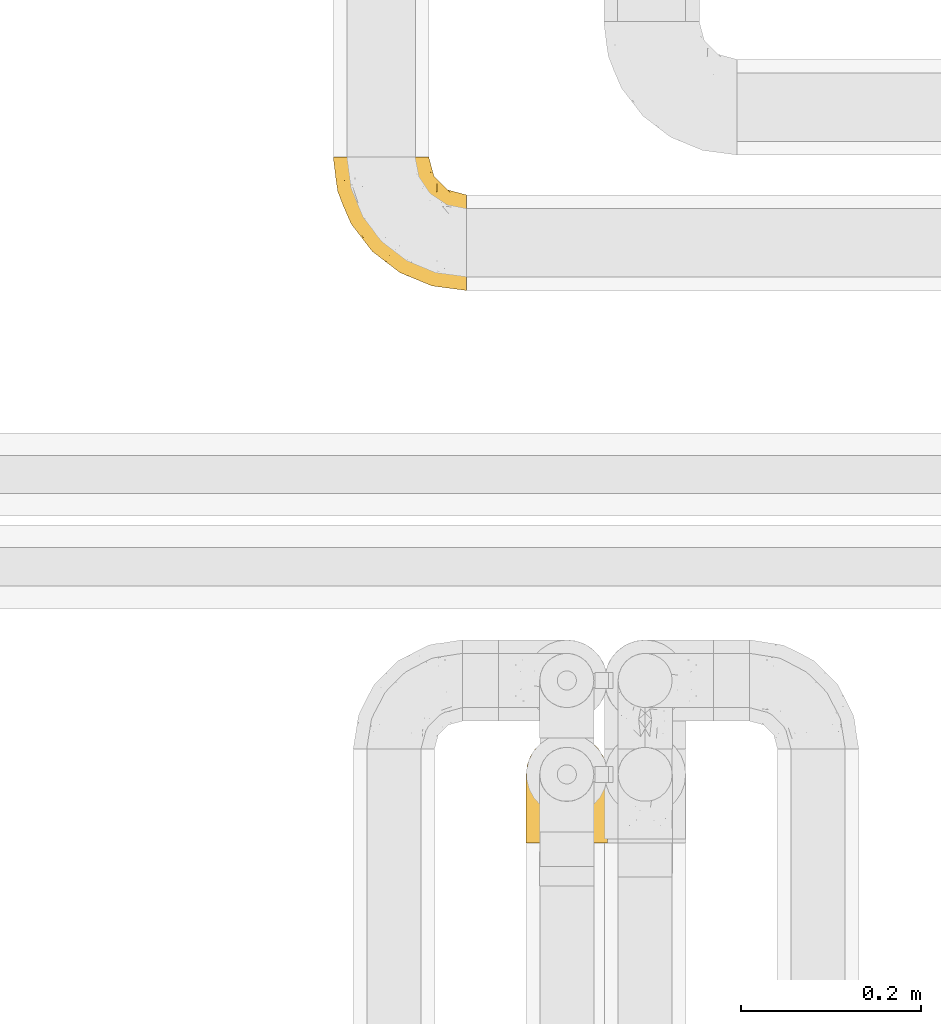
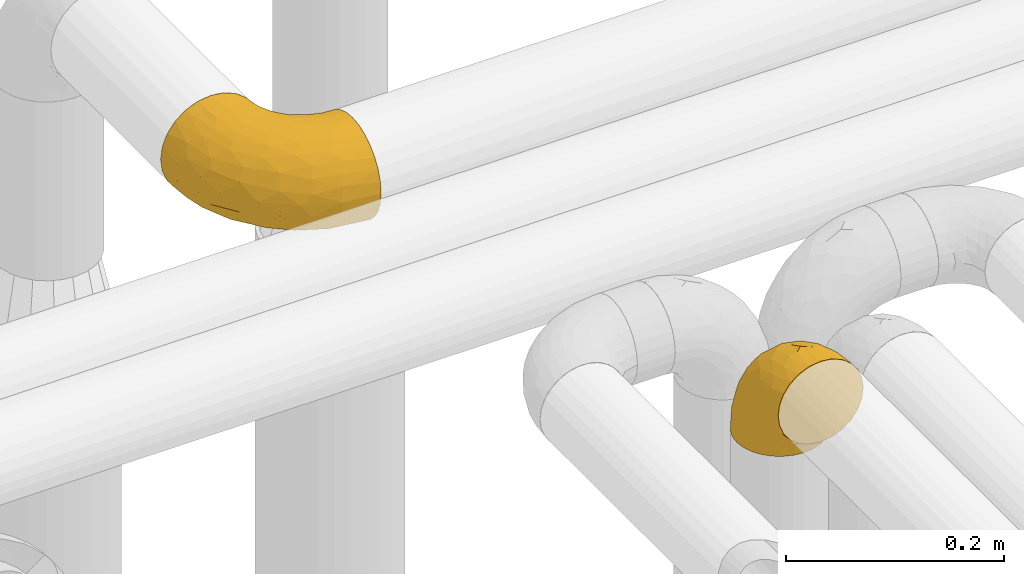
# One storey, part 314 of 827: 2 coverings.
"""IFC2X3 building model written with IfcOpenShell, lengths in millimetres."""

import ifcopenshell
import ifcopenshell.guid

model = None  # the IFC model being written
_history = None  # IfcOwnerHistory: only IFC2X3 demands one
_inside = {}  # id of a spatial element -> (the spatial element, [elements in it])
_under = {}  # id of a project, library or spatial element -> (it, [spatial elements below it])
_declared = {}  # id of a project -> (the project, [libraries it declares])
_typed = {}  # id of a type object -> (the type object, [elements of that type])
_made_of = {}  # id of a material, layer set ... -> (it, [elements and type objects made of it])


def new_model(schema):
    """Start an empty IFC model of exactly this schema.

    Asked for "IFC4X3", IfcOpenShell would pick the latest addendum, in which some entities
    have other attributes; the version numbers below select the first issue.
    IFC2X3 requires an IfcOwnerHistory on every rooted entity: one is made here for all.
    """
    global model, _history
    if schema == "IFC4X3":
        model = ifcopenshell.file(schema_version=(4, 3, 0, 0))
    else:
        model = ifcopenshell.file(schema=schema)
    _inside.clear()
    _under.clear()
    _declared.clear()
    _typed.clear()
    _made_of.clear()
    _history = None
    if model.schema == "IFC2X3":
        org = make("IfcOrganization", Name="unknown")
        user = make(
            "IfcPersonAndOrganization",
            ThePerson=make("IfcPerson", FamilyName="unknown"),
            TheOrganization=org,
        )
        app = make(
            "IfcApplication",
            ApplicationDeveloper=org,
            Version="unknown",
            ApplicationFullName="unknown",
            ApplicationIdentifier="unknown",
        )
        _history = make(
            "IfcOwnerHistory",
            OwningUser=user,
            OwningApplication=app,
            ChangeAction="ADDED",
            CreationDate=0,
        )
    return model


def make(cls, **values):
    """One entity of the class cls with the attributes given. An attribute that is None is left unset."""
    return model.create_entity(
        cls, **{name: value for name, value in values.items() if value is not None}
    )


def entity(cls, *values):
    """Any entity or typed value of the class cls, its attributes in the order of the schema. None: left unset."""
    e = model.create_entity(cls)
    for i, value in enumerate(values):
        if value is not None:
            e[i] = value
    return e


def rooted(cls, **values):
    """An entity with a GlobalId (a new one), such as an element, a storey or a relation."""
    return make(cls, GlobalId=ifcopenshell.guid.new(), OwnerHistory=_history, **values)


def si_unit(unit_type, name, prefix=None):
    """IfcSIUnit, for example si_unit("LENGTHUNIT", "METRE", prefix="MILLI")."""
    return make("IfcSIUnit", UnitType=unit_type, Prefix=prefix, Name=name)


def converted_unit(unit_type, name, factor, base, dimensions=None, offset=None):
    """IfcConversionBasedUnit, such as the inch: factor (a typed value) times the base unit."""
    return make(
        "IfcConversionBasedUnit"
        if offset is None
        else "IfcConversionBasedUnitWithOffset",
        ConversionOffset=offset,
        Dimensions=None
        if dimensions is None
        else entity("IfcDimensionalExponents", *dimensions),
        UnitType=unit_type,
        Name=name,
        ConversionFactor=make(
            "IfcMeasureWithUnit", ValueComponent=factor, UnitComponent=base
        ),
    )


def derived_unit(unit_type, elements):
    """IfcDerivedUnit: a product of units, each with its exponent."""
    return make(
        "IfcDerivedUnit",
        Elements=[
            make("IfcDerivedUnitElement", Unit=unit, Exponent=power)
            for unit, power in elements
        ],
        UnitType=unit_type,
    )


def assignment(units):
    """IfcUnitAssignment: the units of a project."""
    return None if units is None else make("IfcUnitAssignment", Units=units)


def point(xyz):
    """IfcCartesianPoint."""
    return None if xyz is None else make("IfcCartesianPoint", Coordinates=xyz)


def direction(xyz):
    """IfcDirection."""
    return None if xyz is None else make("IfcDirection", DirectionRatios=xyz)


def frame(location, z_axis=None, x_axis=None):
    """IfcAxis2Placement3D, a coordinate frame: its origin and axes. An axis left out is left unset."""
    return make(
        "IfcAxis2Placement3D",
        Location=point(location),
        Axis=direction(z_axis),
        RefDirection=direction(x_axis),
    )


def origin():
    """The frame at (0, 0, 0) with its axes left unset."""
    return frame((0.0, 0.0, 0.0))


def place(relative_to, where):
    """IfcLocalPlacement: puts the frame where relative to a parent placement (None: the world)."""
    return make(
        "IfcLocalPlacement", PlacementRelTo=relative_to, RelativePlacement=where
    )


def context(
    kind, dimensions, precision=None, world=None, true_north=None, identifier=None
):
    """IfcGeometricRepresentationContext, for example the 3D "Model" context."""
    return make(
        "IfcGeometricRepresentationContext",
        ContextIdentifier=identifier,
        ContextType=kind,
        CoordinateSpaceDimension=dimensions,
        Precision=precision,
        WorldCoordinateSystem=world,
        TrueNorth=true_north,
    )


def subcontext(parent, identifier, kind, view, scale=None):
    """IfcGeometricRepresentationSubContext, for example "Body" below "Model"."""
    return make(
        "IfcGeometricRepresentationSubContext",
        ContextIdentifier=identifier,
        ContextType=kind,
        ParentContext=parent,
        TargetScale=scale,
        TargetView=view,
    )


def project(units=None, contexts=None):
    """IfcProject with its units and contexts."""
    return rooted(
        "IfcProject",
        Name="project",
        RepresentationContexts=contexts,
        UnitsInContext=assignment(units),
    )


def spatial(cls, under=None, at=None, **own):
    """A site, building, storey or space (cls), placed at a placement, below another one or the project."""
    s = rooted(cls, ObjectPlacement=at, **own)
    if under is not None:
        _under.setdefault(under.id(), (under, []))[1].append(s)
    return s


def faces_of(points, faces, orient=None, outer=None):
    """IfcFace entities. A face is a list of loops; a loop is a list of indices into points, from 0.

    orient and outer hold one flag for each loop. By default every Orientation is true, the
    first loop of a face is its IfcFaceOuterBound and the others are IfcFaceBound.
    """
    made = []
    for i, loops in enumerate(faces):
        bounds = []
        for j, loop in enumerate(loops):
            is_outer = j == 0 if outer is None else outer[i][j]
            bounds.append(
                make(
                    "IfcFaceOuterBound" if is_outer else "IfcFaceBound",
                    Bound=make("IfcPolyLoop", Polygon=[points[k] for k in loop]),
                    Orientation=True if orient is None else orient[i][j],
                )
            )
        made.append(make("IfcFace", Bounds=bounds))
    return made


def faceted_brep(points, faces, orient=None, outer=None, voids=None):
    """IfcFacetedBrep: a solid bounded by flat faces; with voids (closed shells), ...WithVoids."""
    shared = [point(p) for p in points]
    hull = make("IfcClosedShell", CfsFaces=faces_of(shared, faces, orient, outer))
    if voids is None:
        return make("IfcFacetedBrep", Outer=hull)
    return make(
        "IfcFacetedBrepWithVoids",
        Outer=hull,
        Voids=[
            make(cls, CfsFaces=faces_of(shared, fs, o, b)) for cls, fs, o, b in voids
        ],
    )


def shape(context_of_items, identifier, shape_type, items):
    """IfcShapeRepresentation: the items that make up one representation, for example the "Body"."""
    return make(
        "IfcShapeRepresentation",
        ContextOfItems=context_of_items,
        RepresentationIdentifier=identifier,
        RepresentationType=shape_type,
        Items=items,
    )


def made_of(thing, what):
    """Note that an element or type object is made of a material, layer set ...; save() writes the relation."""
    if what is not None:
        _made_of.setdefault(what.id(), (what, []))[1].append(thing)
    return thing


def element(
    cls,
    number,
    at=None,
    inside=None,
    cuts=None,
    type_object=None,
    material=None,
    context=None,
    identifier="Body",
    shape_type=None,
    held_by="IfcProductDefinitionShape",
    body=None,
    shapes=None,
    **own,
):
    """One element of the class cls, such as IfcWall. Its Tag is "e" and its number.

    at: its placement. inside: the storey or other place that contains it. cuts: it is an
    opening in that element (IfcRelVoidsElement). A single representation is given by context,
    identifier, shape_type and body (its items); several are given by shapes. held_by: the class
    of the entity that holds the representations. save() writes the other relations.
    """
    e = rooted(cls, Tag="e%d" % number, ObjectPlacement=at, **own)
    if body is not None:
        shapes = [shape(context, identifier, shape_type, body)]
    if shapes is not None:
        e.Representation = make(held_by, Representations=shapes)
    if inside is not None:
        _inside.setdefault(inside.id(), (inside, []))[1].append(e)
    if cuts is not None:
        rooted(
            "IfcRelVoidsElement", RelatingBuildingElement=cuts, RelatedOpeningElement=e
        )
    if type_object is not None:
        _typed.setdefault(type_object.id(), (type_object, []))[1].append(e)
    return made_of(e, material)


def aggregate(whole, parts):
    """IfcRelAggregates: a whole, such as a stair, and the parts it consists of."""
    return rooted("IfcRelAggregates", RelatingObject=whole, RelatedObjects=parts)


def save(model, path):
    """Write the relations noted so far, then the file.

    IfcRelAggregates (storeys below a building ...), IfcRelContainedInSpatialStructure (elements
    in a storey), IfcRelDefinesByType, IfcRelAssociatesMaterial and IfcRelDeclares: one each for
    every whole, place, type object, material and project.
    """
    for whole, parts in _under.values():
        aggregate(whole, parts)
    for where, things in _inside.values():
        rooted(
            "IfcRelContainedInSpatialStructure",
            RelatedElements=things,
            RelatingStructure=where,
        )
    for kind, things in _typed.values():
        rooted("IfcRelDefinesByType", RelatedObjects=things, RelatingType=kind)
    for what, things in _made_of.values():
        rooted("IfcRelAssociatesMaterial", RelatedObjects=things, RelatingMaterial=what)
    for by, libraries in _declared.values():
        rooted("IfcRelDeclares", RelatingContext=by, RelatedDefinitions=libraries)
    model.write(path)


model = new_model("IFC2X3")

# Units and contexts
model_context = context("Model", 3, precision=0.01, world=origin(), true_north=direction((6.12303176911189e-17, 1.0)))
body_context = subcontext(model_context, "Body", "Model", "MODEL_VIEW")
ifc_project = project(units=[si_unit("LENGTHUNIT", "METRE", prefix="MILLI"), si_unit("AREAUNIT", "SQUARE_METRE"), si_unit("VOLUMEUNIT", "CUBIC_METRE"), converted_unit("PLANEANGLEUNIT", "DEGREE", entity("IfcRatioMeasure", 0.0174532925199433), si_unit("PLANEANGLEUNIT", "RADIAN"), dimensions=[0, 0, 0, 0, 0, 0, 0]), si_unit("MASSUNIT", "GRAM", prefix="KILO"), derived_unit("MASSDENSITYUNIT", [(si_unit("MASSUNIT", "GRAM", prefix="KILO"), 1), (si_unit("LENGTHUNIT", "METRE"), -3)]), derived_unit("MOMENTOFINERTIAUNIT", [(si_unit("LENGTHUNIT", "METRE"), 4)]), si_unit("TIMEUNIT", "SECOND"), si_unit("FREQUENCYUNIT", "HERTZ"), si_unit("THERMODYNAMICTEMPERATUREUNIT", "DEGREE_CELSIUS"), derived_unit("THERMALTRANSMITTANCEUNIT", [(si_unit("MASSUNIT", "GRAM", prefix="KILO"), 1), (si_unit("THERMODYNAMICTEMPERATUREUNIT", "KELVIN"), -1), (si_unit("TIMEUNIT", "SECOND"), -3)]), derived_unit("VOLUMETRICFLOWRATEUNIT", [(si_unit("LENGTHUNIT", "METRE"), 3), (si_unit("TIMEUNIT", "SECOND"), -1)]), derived_unit("MASSFLOWRATEUNIT", [(si_unit("MASSUNIT", "GRAM", prefix="KILO"), 1), (si_unit("TIMEUNIT", "SECOND"), -1)]), derived_unit("ROTATIONALFREQUENCYUNIT", [(si_unit("TIMEUNIT", "SECOND"), -1)]), si_unit("ELECTRICCURRENTUNIT", "AMPERE"), si_unit("ELECTRICVOLTAGEUNIT", "VOLT"), si_unit("POWERUNIT", "WATT"), si_unit("FORCEUNIT", "NEWTON", prefix="KILO"), si_unit("ILLUMINANCEUNIT", "LUX"), si_unit("LUMINOUSFLUXUNIT", "LUMEN"), si_unit("LUMINOUSINTENSITYUNIT", "CANDELA"), derived_unit("USERDEFINED", [(si_unit("MASSUNIT", "GRAM", prefix="KILO"), -1), (si_unit("LENGTHUNIT", "METRE"), -2), (si_unit("TIMEUNIT", "SECOND"), 3), (si_unit("LUMINOUSFLUXUNIT", "LUMEN"), 1)]), derived_unit("LINEARVELOCITYUNIT", [(si_unit("LENGTHUNIT", "METRE"), 1), (si_unit("TIMEUNIT", "SECOND"), -1)]), si_unit("PRESSUREUNIT", "PASCAL"), derived_unit("USERDEFINED", [(si_unit("LENGTHUNIT", "METRE"), -2), (si_unit("MASSUNIT", "GRAM", prefix="KILO"), 1), (si_unit("TIMEUNIT", "SECOND"), -2)]), derived_unit("LINEARFORCEUNIT", [(si_unit("MASSUNIT", "GRAM", prefix="KILO"), 1), (si_unit("LENGTHUNIT", "METRE"), 1), (si_unit("TIMEUNIT", "SECOND"), -2), (si_unit("LENGTHUNIT", "METRE"), -1)]), derived_unit("PLANARFORCEUNIT", [(si_unit("MASSUNIT", "GRAM", prefix="KILO"), 1), (si_unit("LENGTHUNIT", "METRE"), 1), (si_unit("TIMEUNIT", "SECOND"), -2), (si_unit("LENGTHUNIT", "METRE"), -2)])], contexts=[model_context])

# Site, building, storey
site_placement = place(None, origin())
site = spatial("IfcSite", under=ifc_project, at=site_placement, CompositionType="ELEMENT")
building_placement = place(site_placement, origin())
building = spatial("IfcBuilding", under=site, at=building_placement, CompositionType="ELEMENT")
storey_placement = place(building_placement, frame((0.0, 0.0, 28200.0)))
storey = spatial("IfcBuildingStorey", under=building, at=storey_placement, Name="08", CompositionType="ELEMENT", Elevation=28200.0)

# Coverings
covering_1_placement = place(storey_placement, frame((31614.92, 18289.35, 2922.4)))
element("IfcCovering", 1, at=covering_1_placement, inside=storey, Name=":ADSK_", ObjectType=":ADSK_", PredefinedType="INSULATION", context=body_context, shape_type="Brep", body=[
    faceted_brep([(2.73, 87.65, 1.6), (6.07, 97.19, 1.6), (11.45, 105.75, 1.6), (18.6, 112.9, 1.6), (27.16, 118.28, 1.6), (36.7, 121.61, 1.6), (46.75, 122.75, 1.6), (56.8, 121.61, 1.6), (66.34, 118.27, 1.6), (74.9, 112.89, 1.6), (82.05, 105.74, 1.6), (87.43, 97.18, 1.6), (90.76, 87.64, 1.6), (91.9, 77.6, 1.6), (90.76, 67.54, 1.6), (87.42, 58.0, 1.6), (82.04, 49.44, 1.6), (74.89, 42.29, 1.6), (66.33, 36.91, 1.6), (56.79, 33.58, 1.6), (46.75, 32.45, 1.6), (36.69, 33.58, 1.6), (27.15, 36.92, 1.6), (18.59, 42.3, 1.6), (11.44, 49.45, 1.6), (6.06, 58.01, 1.6), (2.73, 67.55, 1.6), (1.6, 77.6, 1.6), (58.43, 1.6, 33.98), (69.32, 1.6, 38.49), (78.67, 1.6, 45.67), (85.85, 1.6, 55.02), (90.36, 1.6, 65.91), (91.9, 1.6, 77.6), (90.36, 1.6, 89.28), (85.85, 1.6, 100.17), (78.67, 1.6, 109.52), (69.32, 1.6, 116.7), (58.43, 1.6, 121.21), (46.75, 1.6, 122.75), (35.06, 1.6, 121.21), (24.17, 1.6, 116.7), (14.82, 1.6, 109.52), (7.64, 1.6, 100.17), (3.13, 1.6, 89.28), (1.6, 1.6, 77.6), (3.13, 1.6, 65.91), (7.64, 1.6, 55.02), (14.82, 1.6, 45.67), (24.17, 1.6, 38.49), (35.06, 1.6, 33.98), (46.75, 1.6, 32.45), (46.75, 99.61, 72.81), (38.29, 95.26, 77.17), (46.75, 86.21, 86.21), (46.75, 39.03, 116.82), (38.96, 30.75, 118.49), (46.75, 23.8, 119.23), (33.86, 60.8, 105.14), (31.42, 85.37, 85.37), (21.63, 73.64, 89.33), (30.84, 31.01, 116.14), (22.16, 49.14, 105.06), (20.56, 23.88, 112.15), (2.29, 82.74, 22.95), (7.18, 43.48, 89.91), (12.6, 29.47, 103.39), (14.0, 56.38, 93.6), (2.81, 72.18, 51.41), (6.65, 72.24, 67.71), (6.11, 87.6, 43.53), (16.62, 107.24, 30.91), (9.76, 101.1, 23.58), (12.46, 95.16, 50.07), (1.6, 71.81, 30.68), (1.6, 63.57, 43.01), (1.6, 55.34, 55.34), (2.46, 23.66, 83.48), (5.91, 20.55, 94.96), (36.97, 107.97, 57.29), (46.75, 116.82, 39.03), (33.09, 117.03, 30.66), (1.6, 30.68, 71.81), (1.6, 21.51, 73.63), (1.6, 12.33, 75.46), (25.62, 106.17, 51.57), (3.14, 52.37, 73.13), (23.92, 114.51, 23.16), (46.75, 119.23, 23.8), (13.58, 78.37, 75.6), (1.6, 75.46, 12.33), (1.6, 73.63, 21.51), (18.5, 101.51, 50.46), (46.75, 72.81, 99.61), (1.6, 43.01, 63.57), (4.96, 92.6, 21.26), (20.84, 91.86, 69.54), (46.75, 55.92, 108.21), (30.52, 99.01, 68.42), (46.75, 108.21, 55.92), (27.29, 32.05, 19.36), (36.89, 30.22, 15.76), (33.6, 23.37, 26.13), (2.54, 28.43, 62.78), (3.27, 16.44, 63.65), (16.85, 37.1, 24.34), (21.91, 28.88, 28.46), (13.5, 33.93, 33.53), (3.96, 50.17, 39.46), (3.52, 40.57, 51.05), (12.17, 47.62, 10.94), (18.93, 39.9, 14.55), (9.34, 47.92, 22.21), (3.12, 34.27, 57.05), (5.67, 24.65, 54.0), (2.51, 62.6, 29.19), (2.53, 66.18, 18.85), (8.35, 11.74, 52.84), (35.39, 13.89, 31.47), (46.75, 17.02, 28.31), (15.1, 15.86, 43.0), (5.27, 57.71, 16.9), (27.43, 9.11, 35.98), (24.89, 18.55, 33.91), (29.71, 34.74, 9.97), (5.07, 54.95, 25.93), (2.88, 57.35, 35.61), (9.69, 22.03, 47.45), (15.51, 24.8, 38.26), (2.27, 69.07, 11.7), (10.03, 42.31, 30.13), (46.75, 29.63, 12.12), (46.75, 28.31, 17.02), (8.83, 30.23, 44.39), (7.16, 40.13, 39.83), (46.75, 22.67, 22.67), (46.75, 12.12, 29.63), (78.39, 15.86, 43.0), (83.8, 22.03, 47.45), (77.97, 24.8, 38.26), (84.66, 30.23, 44.38), (58.1, 13.88, 31.47), (81.31, 47.61, 10.93), (91.9, 73.63, 21.51), (90.96, 66.17, 18.84), (91.22, 69.07, 11.7), (56.59, 30.22, 15.76), (66.18, 32.04, 19.36), (59.87, 23.36, 26.14), (88.42, 54.93, 25.94), (84.13, 47.91, 22.21), (88.22, 57.69, 16.9), (66.06, 9.1, 35.98), (91.9, 21.51, 73.63), (91.9, 12.33, 75.46), (83.44, 42.29, 30.12), (76.62, 37.09, 24.33), (85.14, 11.74, 52.84), (90.22, 16.44, 63.65), (91.9, 30.68, 71.81), (71.55, 28.86, 28.45), (63.77, 34.74, 9.97), (91.9, 63.57, 43.01), (91.9, 55.34, 55.34), (89.53, 50.17, 39.46), (91.9, 75.46, 12.33), (74.55, 39.89, 14.54), (90.95, 28.43, 62.78), (90.37, 34.27, 57.05), (91.9, 43.01, 63.57), (90.98, 62.59, 29.2), (89.97, 40.57, 51.05), (86.32, 40.13, 39.81), (91.9, 71.81, 30.68), (79.97, 33.92, 33.52), (90.61, 57.34, 35.61), (87.82, 24.65, 54.0), (68.6, 18.54, 33.91), (80.89, 29.47, 103.39), (86.31, 43.48, 89.91), (79.49, 56.4, 93.6), (71.33, 49.17, 105.05), (71.88, 73.69, 89.27), (90.35, 52.37, 73.13), (86.85, 72.26, 67.67), (72.67, 91.88, 69.49), (62.08, 85.36, 85.36), (87.58, 20.55, 94.96), (91.03, 23.66, 83.48), (59.62, 60.8, 105.14), (62.65, 31.02, 116.13), (54.53, 30.75, 118.49), (72.93, 23.9, 112.15), (90.68, 72.17, 51.41), (87.39, 87.59, 43.51), (91.2, 82.74, 22.95), (60.41, 117.03, 30.66), (76.88, 107.23, 30.91), (56.53, 107.97, 57.3), (83.74, 101.08, 23.58), (67.88, 106.17, 51.56), (62.99, 99.01, 68.41), (69.58, 114.5, 23.16), (81.04, 95.15, 50.07), (75.0, 101.5, 50.45), (88.53, 92.59, 21.25), (79.93, 78.38, 75.56), (55.21, 95.27, 77.16)], [[[0, 1, 2, 3, 4, 5, 6, 7, 8, 9, 10, 11, 12, 13, 14, 15, 16, 17, 18, 19, 20, 21, 22, 23, 24, 25, 26, 27]], [[28, 29, 30, 31, 32, 33, 34, 35, 36, 37, 38, 39, 40, 41, 42, 43, 44, 45, 46, 47, 48, 49, 50, 51]], [[52, 53, 54]], [[55, 56, 57]], [[58, 59, 60]], [[61, 62, 63]], [[27, 64, 0]], [[65, 66, 67]], [[41, 40, 61]], [[68, 69, 70]], [[66, 43, 42]], [[63, 42, 41]], [[71, 72, 73]], [[72, 2, 1]], [[68, 74, 75, 76]], [[45, 44, 77]], [[43, 78, 44]], [[79, 80, 81]], [[77, 82, 83, 84, 45]], [[79, 81, 85]], [[71, 2, 72]], [[65, 86, 77]], [[4, 81, 5]], [[66, 65, 78]], [[4, 3, 87]], [[81, 88, 5]], [[63, 66, 42]], [[68, 70, 64]], [[67, 60, 89]], [[71, 3, 2]], [[64, 27, 90, 91, 74]], [[92, 71, 73]], [[40, 57, 56]], [[59, 93, 54]], [[86, 76, 94, 82]], [[1, 0, 95]], [[58, 62, 61]], [[60, 96, 89]], [[85, 81, 87]], [[56, 97, 58]], [[65, 67, 69]], [[87, 81, 4]], [[67, 89, 69]], [[61, 63, 41]], [[95, 72, 1]], [[73, 72, 70]], [[69, 73, 70]], [[73, 89, 96]], [[3, 71, 87]], [[85, 87, 71]], [[58, 61, 56]], [[59, 58, 93]], [[76, 86, 68]], [[69, 89, 73]], [[68, 86, 69]], [[65, 69, 86]], [[68, 64, 74]], [[95, 64, 70]], [[98, 79, 85]], [[79, 52, 99, 80]], [[66, 62, 67]], [[62, 58, 60]], [[62, 60, 67]], [[59, 98, 96]], [[59, 96, 60]], [[96, 85, 92]], [[88, 81, 80]], [[88, 6, 5]], [[66, 63, 62]], [[64, 95, 0]], [[72, 95, 70]], [[77, 44, 78]], [[86, 82, 77]], [[40, 39, 57]], [[96, 98, 85]], [[40, 56, 61]], [[66, 78, 43]], [[77, 78, 65]], [[79, 98, 53]], [[96, 92, 73]], [[85, 71, 92]], [[97, 56, 55]], [[97, 93, 58]], [[53, 98, 59]], [[54, 53, 59]], [[79, 53, 52]], [[100, 101, 102]], [[46, 45, 84, 83]], [[103, 104, 82]], [[82, 104, 83]], [[105, 106, 107]], [[108, 109, 76]], [[110, 111, 112]], [[103, 113, 114]], [[115, 74, 116]], [[48, 47, 117]], [[118, 102, 119]], [[49, 48, 120]], [[74, 91, 116]], [[116, 121, 115]], [[49, 122, 50]], [[123, 106, 102]], [[124, 111, 22]], [[125, 126, 115]], [[23, 22, 111]], [[24, 110, 121]], [[120, 127, 128]], [[90, 26, 129]], [[27, 26, 90]], [[121, 125, 115]], [[24, 121, 25]], [[130, 105, 107]], [[129, 25, 116]], [[21, 20, 131]], [[120, 123, 122]], [[112, 105, 130]], [[50, 118, 51]], [[21, 124, 22]], [[101, 131, 132]], [[117, 120, 48]], [[24, 23, 110]], [[127, 114, 133]], [[75, 108, 76]], [[107, 134, 130]], [[133, 114, 113]], [[129, 116, 91]], [[25, 121, 116]], [[121, 112, 125]], [[75, 74, 115]], [[101, 135, 102]], [[131, 101, 21]], [[101, 100, 124]], [[128, 127, 133]], [[119, 136, 51, 118]], [[104, 47, 46]], [[83, 104, 46]], [[117, 104, 114]], [[101, 124, 21]], [[111, 124, 100]], [[102, 118, 123]], [[133, 134, 107]], [[111, 110, 23]], [[114, 104, 103]], [[94, 76, 109]], [[121, 110, 112]], [[122, 118, 50]], [[134, 109, 108]], [[133, 107, 128]], [[112, 108, 125]], [[126, 125, 108]], [[108, 75, 126]], [[75, 115, 126]], [[109, 134, 133]], [[130, 108, 112]], [[108, 130, 134]], [[105, 112, 111]], [[111, 100, 105]], [[106, 105, 100]], [[102, 106, 100]], [[128, 106, 123]], [[90, 129, 91]], [[25, 129, 26]], [[104, 117, 47]], [[117, 114, 127]], [[82, 94, 103]], [[113, 94, 109]], [[94, 113, 103]], [[133, 113, 109]], [[106, 128, 107]], [[123, 120, 128]], [[120, 122, 49]], [[118, 122, 123]], [[135, 101, 132]], [[135, 119, 102]], [[117, 127, 120]], [[30, 29, 137]], [[138, 139, 140]], [[51, 136, 119, 141]], [[142, 17, 16]], [[143, 144, 145]], [[146, 147, 148]], [[149, 150, 151]], [[152, 29, 28]], [[33, 32, 153, 154]], [[150, 155, 156]], [[157, 31, 30]], [[153, 158, 159]], [[29, 152, 137]], [[148, 141, 119]], [[156, 160, 147]], [[148, 135, 146]], [[137, 138, 157]], [[19, 161, 146]], [[162, 163, 164]], [[14, 13, 165]], [[153, 32, 158]], [[147, 161, 166]], [[18, 17, 166]], [[167, 168, 169]], [[166, 150, 156]], [[151, 150, 142]], [[151, 170, 149]], [[151, 16, 15]], [[171, 140, 172]], [[165, 143, 145]], [[173, 170, 144]], [[142, 166, 17]], [[19, 131, 20]], [[144, 170, 151]], [[18, 161, 19]], [[173, 144, 143]], [[140, 139, 174]], [[171, 164, 163]], [[164, 172, 155]], [[151, 15, 144]], [[145, 15, 14]], [[173, 162, 170]], [[149, 175, 164]], [[19, 146, 131]], [[132, 131, 146]], [[160, 148, 147]], [[159, 158, 167]], [[135, 132, 146]], [[158, 32, 31]], [[157, 158, 31]], [[167, 158, 176]], [[166, 161, 18]], [[146, 161, 147]], [[148, 177, 141]], [[171, 168, 140]], [[171, 163, 169]], [[151, 142, 16]], [[166, 142, 150]], [[152, 141, 177]], [[51, 141, 28]], [[138, 140, 176]], [[172, 140, 174]], [[175, 149, 170]], [[164, 150, 149]], [[170, 162, 175]], [[162, 164, 175]], [[155, 172, 174]], [[171, 172, 164]], [[155, 174, 156]], [[164, 155, 150]], [[160, 156, 174]], [[147, 166, 156]], [[139, 160, 174]], [[148, 160, 177]], [[15, 145, 144]], [[165, 145, 14]], [[137, 157, 30]], [[158, 157, 176]], [[168, 167, 176]], [[169, 159, 167]], [[140, 168, 176]], [[169, 168, 171]], [[137, 177, 139]], [[160, 139, 177]], [[141, 152, 28]], [[137, 152, 177]], [[148, 119, 135]], [[157, 138, 176]], [[139, 138, 137]], [[178, 179, 180]], [[181, 180, 182]], [[179, 183, 184]], [[185, 186, 182]], [[187, 188, 179]], [[188, 33, 154, 153, 159]], [[181, 189, 190]], [[35, 34, 187]], [[191, 38, 190]], [[192, 178, 181]], [[179, 184, 180]], [[192, 190, 37]], [[37, 190, 38]], [[36, 35, 178]], [[54, 93, 186]], [[35, 187, 178]], [[193, 194, 184]], [[195, 173, 143, 165, 13]], [[195, 193, 173]], [[193, 163, 162, 173]], [[13, 12, 195]], [[8, 7, 196]], [[9, 197, 10]], [[198, 80, 99, 52]], [[196, 7, 88]], [[197, 199, 10]], [[182, 189, 181]], [[200, 198, 201]], [[200, 196, 198]], [[9, 8, 202]], [[194, 199, 203]], [[192, 37, 36]], [[80, 196, 88]], [[183, 159, 169, 163]], [[188, 34, 33]], [[202, 200, 197]], [[185, 203, 204]], [[202, 8, 196]], [[10, 199, 11]], [[12, 11, 205]], [[38, 191, 57]], [[189, 97, 191]], [[203, 199, 197]], [[205, 199, 194]], [[204, 203, 197]], [[184, 203, 206]], [[200, 202, 196]], [[197, 9, 202]], [[207, 54, 186]], [[97, 55, 191]], [[194, 203, 184]], [[183, 163, 193]], [[184, 206, 180]], [[183, 193, 184]], [[205, 195, 12]], [[193, 195, 194]], [[80, 198, 196]], [[207, 186, 201]], [[182, 180, 206]], [[181, 178, 180]], [[185, 182, 206]], [[182, 186, 189]], [[203, 185, 206]], [[185, 200, 201]], [[7, 6, 88]], [[178, 192, 36]], [[190, 192, 181]], [[199, 205, 11]], [[195, 205, 194]], [[159, 183, 188]], [[179, 188, 183]], [[57, 191, 55]], [[57, 39, 38]], [[189, 191, 190]], [[188, 187, 34]], [[178, 187, 179]], [[186, 93, 189]], [[197, 200, 204]], [[185, 204, 200]], [[189, 93, 97]], [[207, 198, 52]], [[185, 201, 186]], [[198, 207, 201]], [[54, 207, 52]]]),
])
covering_2_placement = place(storey_placement, frame((31400.76, 18902.59, 2845.44)))
element("IfcCovering", 2, at=covering_2_placement, inside=storey, Name=":ADSK_", ObjectType=":ADSK_", PredefinedType="INSULATION", context=body_context, shape_type="Brep", body=[
    faceted_brep([(149.65, 2.92, 66.44), (149.65, 1.6, 54.65), (149.65, 2.93, 42.84), (149.65, 6.85, 31.62), (149.65, 13.18, 21.56), (149.65, 21.58, 13.16), (149.65, 31.64, 6.84), (149.65, 42.85, 2.92), (149.65, 54.65, 1.6), (149.65, 66.46, 2.93), (149.65, 77.67, 6.85), (149.65, 87.73, 13.18), (149.65, 96.13, 21.58), (149.65, 102.45, 31.64), (149.65, 106.37, 42.85), (149.65, 107.7, 54.65), (149.65, 106.36, 66.46), (149.65, 102.44, 77.67), (149.65, 96.11, 87.73), (149.65, 87.71, 96.13), (149.65, 77.65, 102.45), (149.65, 66.44, 106.37), (149.65, 54.65, 107.7), (149.65, 42.84, 106.36), (149.65, 31.62, 102.44), (149.65, 21.56, 96.11), (149.65, 13.16, 87.71), (149.65, 6.84, 77.65), (105.89, 149.65, 40.91), (100.59, 149.65, 28.12), (92.16, 149.65, 17.13), (81.17, 149.65, 8.7), (68.38, 149.65, 3.4), (54.65, 149.65, 1.6), (40.91, 149.65, 3.4), (28.12, 149.65, 8.7), (17.13, 149.65, 17.13), (8.7, 149.65, 28.12), (3.4, 149.65, 40.91), (1.6, 149.65, 54.65), (3.4, 149.65, 68.38), (8.7, 149.65, 81.17), (17.13, 149.65, 92.16), (28.12, 149.65, 100.59), (40.91, 149.65, 105.89), (54.65, 149.65, 107.7), (68.38, 149.65, 105.89), (81.17, 149.65, 100.59), (92.16, 149.65, 92.16), (100.59, 149.65, 81.17), (105.89, 149.65, 68.38), (107.7, 149.65, 54.65), (14.05, 123.27, 85.53), (9.45, 114.15, 73.42), (22.36, 92.97, 83.77), (4.7, 124.11, 64.22), (6.64, 111.33, 54.65), (81.47, 42.13, 96.72), (56.83, 56.83, 93.36), (64.02, 40.31, 84.47), (34.04, 61.55, 71.37), (21.43, 75.62, 54.65), (44.96, 44.96, 54.65), (49.8, 91.12, 103.47), (35.43, 109.83, 100.91), (42.1, 88.02, 99.1), (43.59, 119.19, 105.43), (57.88, 99.11, 106.79), (91.8, 27.97, 89.81), (88.01, 21.92, 79.59), (115.65, 12.94, 81.29), (18.94, 88.29, 74.01), (12.83, 95.35, 64.14), (24.96, 113.84, 94.75), (111.33, 6.64, 54.65), (113.8, 8.58, 70.74), (60.89, 33.39, 68.3), (86.24, 17.23, 66.05), (65.84, 61.99, 100.73), (124.58, 47.9, 106.78), (121.36, 37.72, 103.6), (72.79, 93.81, 107.7), (66.04, 107.05, 107.7), (59.29, 120.29, 107.7), (73.26, 73.26, 106.07), (121.69, 18.58, 90.59), (109.82, 29.72, 97.43), (40.11, 64.31, 84.51), (36.57, 82.84, 93.3), (93.81, 72.79, 107.7), (83.3, 83.3, 107.7), (136.6, 56.71, 107.7), (120.29, 59.29, 107.7), (99.11, 57.88, 106.79), (107.05, 66.04, 107.7), (91.12, 49.8, 103.47), (75.62, 21.43, 54.65), (56.97, 134.97, 107.7), (126.65, 108.79, 76.99), (116.55, 110.84, 84.28), (120.09, 101.53, 91.11), (76.06, 111.84, 106.26), (83.69, 119.98, 102.6), (71.88, 123.54, 106.08), (66.92, 134.54, 106.56), (110.43, 80.57, 105.36), (121.31, 69.55, 106.74), (81.0, 134.56, 101.59), (113.32, 128.67, 54.65), (111.09, 136.98, 54.65), (109.14, 133.56, 67.71), (95.86, 131.66, 91.36), (99.07, 117.75, 94.33), (106.92, 118.23, 87.1), (131.39, 110.55, 65.84), (136.98, 111.09, 54.65), (128.67, 113.32, 54.65), (117.07, 120.2, 68.92), (96.39, 105.95, 100.82), (106.61, 127.69, 79.83), (103.72, 139.88, 77.13), (92.14, 92.14, 105.9), (107.13, 93.82, 101.53), (98.03, 82.28, 106.72), (88.38, 130.86, 97.75), (130.66, 78.78, 103.08), (135.45, 67.58, 106.39), (123.57, 90.58, 98.1), (137.75, 90.23, 95.02), (133.2, 99.39, 86.9), (138.8, 105.17, 74.42), (120.99, 120.99, 54.65), (84.53, 104.59, 105.28), (108.72, 108.24, 92.87), (95.86, 131.66, 17.93), (130.67, 78.8, 6.22), (109.13, 133.57, 41.58), (93.81, 72.79, 1.6), (98.02, 82.27, 2.57), (110.43, 80.59, 3.94), (131.4, 110.55, 43.46), (126.66, 108.79, 32.32), (117.08, 120.2, 40.38), (108.74, 108.25, 16.44), (96.31, 106.06, 8.47), (99.11, 117.78, 15.01), (123.58, 90.6, 11.21), (107.12, 93.87, 7.78), (72.79, 93.81, 1.6), (66.04, 107.05, 1.6), (76.07, 111.89, 3.04), (56.97, 134.97, 1.6), (66.92, 134.54, 2.73), (120.29, 59.29, 1.6), (107.05, 66.04, 1.6), (121.26, 69.56, 2.55), (84.46, 104.56, 3.98), (83.69, 119.98, 6.69), (81.0, 134.56, 7.7), (71.88, 123.54, 3.21), (137.76, 90.25, 14.28), (133.21, 99.4, 22.42), (116.58, 110.83, 25.02), (120.1, 101.52, 18.18), (138.81, 105.18, 34.89), (136.6, 56.71, 1.6), (103.72, 139.89, 32.17), (106.96, 118.22, 22.23), (135.44, 67.6, 2.91), (88.38, 130.86, 11.54), (83.3, 83.3, 1.6), (106.6, 127.71, 29.46), (92.12, 92.12, 3.38), (59.29, 120.29, 1.6), (22.36, 92.97, 25.52), (14.05, 123.27, 23.76), (24.96, 113.84, 14.54), (35.43, 109.83, 8.38), (4.71, 124.03, 45.07), (9.45, 114.15, 35.87), (11.79, 98.04, 45.14), (57.88, 99.11, 2.5), (124.57, 47.9, 2.51), (121.37, 37.74, 5.68), (91.12, 49.8, 5.82), (56.83, 56.83, 15.93), (81.48, 42.16, 12.54), (64.05, 40.3, 24.81), (99.11, 57.88, 2.5), (73.26, 73.26, 3.22), (43.59, 119.19, 3.86), (19.5, 86.61, 35.85), (91.8, 27.99, 19.47), (121.7, 18.59, 18.68), (88.04, 21.92, 29.68), (123.34, 11.28, 27.95), (60.89, 33.39, 40.99), (34.04, 61.55, 37.92), (109.85, 29.73, 11.85), (42.1, 88.01, 10.19), (65.78, 62.08, 8.55), (113.81, 8.58, 38.53), (36.57, 82.84, 15.99), (40.12, 64.3, 24.79), (49.8, 91.12, 5.82), (86.08, 18.05, 40.56)], [[[0, 1, 2, 3, 4, 5, 6, 7, 8, 9, 10, 11, 12, 13, 14, 15, 16, 17, 18, 19, 20, 21, 22, 23, 24, 25, 26, 27]], [[28, 29, 30, 31, 32, 33, 34, 35, 36, 37, 38, 39, 40, 41, 42, 43, 44, 45, 46, 47, 48, 49, 50, 51]], [[52, 53, 54]], [[55, 39, 56]], [[57, 58, 59]], [[60, 61, 62]], [[63, 64, 65]], [[66, 63, 67]], [[68, 69, 70]], [[53, 71, 54]], [[41, 40, 53]], [[53, 72, 71]], [[73, 42, 52]], [[42, 41, 52]], [[74, 0, 75]], [[69, 76, 77]], [[43, 73, 64]], [[45, 44, 66]], [[57, 78, 58]], [[23, 79, 80]], [[67, 81, 82, 83]], [[67, 84, 81]], [[24, 23, 80]], [[25, 85, 26]], [[86, 85, 25]], [[42, 73, 43]], [[0, 27, 75]], [[25, 24, 86]], [[70, 26, 85]], [[0, 74, 1]], [[68, 85, 86]], [[66, 64, 63]], [[60, 59, 87]], [[54, 87, 88]], [[76, 60, 62]], [[84, 89, 90, 81]], [[79, 22, 91, 92]], [[77, 74, 75]], [[93, 92, 94, 89]], [[80, 86, 24]], [[40, 55, 53]], [[76, 59, 60]], [[93, 84, 95]], [[76, 62, 96]], [[55, 72, 53]], [[70, 27, 26]], [[75, 70, 69]], [[78, 84, 63]], [[93, 79, 92]], [[95, 86, 80]], [[77, 76, 96]], [[59, 69, 68]], [[57, 68, 86]], [[68, 57, 59]], [[59, 58, 87]], [[76, 69, 59]], [[88, 87, 58]], [[87, 54, 71]], [[86, 95, 57]], [[78, 57, 95]], [[84, 78, 95]], [[78, 63, 65]], [[58, 78, 65]], [[54, 88, 73]], [[84, 93, 89]], [[79, 95, 80]], [[79, 93, 95]], [[22, 79, 23]], [[66, 83, 97, 45]], [[84, 67, 63]], [[83, 66, 67]], [[64, 44, 43]], [[64, 66, 44]], [[65, 73, 88]], [[53, 52, 41]], [[73, 52, 54]], [[73, 65, 64]], [[65, 88, 58]], [[39, 55, 40]], [[72, 55, 56]], [[56, 61, 72]], [[60, 72, 61]], [[72, 60, 71]], [[87, 71, 60]], [[27, 70, 75]], [[68, 70, 85]], [[74, 77, 96]], [[69, 77, 75]], [[98, 99, 100]], [[46, 45, 97]], [[101, 102, 103]], [[103, 104, 83]], [[105, 94, 106]], [[107, 103, 102]], [[108, 109, 51, 110]], [[111, 112, 113]], [[114, 115, 116]], [[47, 104, 107]], [[110, 117, 108]], [[49, 48, 111]], [[102, 118, 112]], [[119, 120, 111]], [[50, 49, 120]], [[121, 122, 118]], [[105, 123, 89]], [[124, 48, 107]], [[20, 19, 125]], [[121, 81, 90]], [[117, 119, 99]], [[21, 20, 126]], [[22, 21, 91]], [[105, 125, 127]], [[110, 51, 50]], [[19, 128, 125]], [[16, 15, 115]], [[129, 98, 100]], [[126, 91, 21]], [[128, 129, 127]], [[122, 123, 105]], [[114, 117, 98]], [[17, 16, 130]], [[18, 128, 19]], [[129, 18, 17]], [[125, 106, 126]], [[115, 114, 16]], [[130, 129, 17]], [[114, 98, 130]], [[117, 116, 131, 108]], [[99, 119, 113]], [[122, 121, 123]], [[92, 126, 106]], [[105, 127, 122]], [[132, 121, 118]], [[114, 130, 16]], [[129, 130, 98]], [[50, 120, 110]], [[129, 128, 18]], [[125, 128, 127]], [[125, 126, 20]], [[91, 126, 92]], [[105, 89, 94]], [[105, 106, 125]], [[94, 92, 106]], [[100, 122, 127]], [[118, 122, 133]], [[112, 118, 133]], [[132, 118, 102]], [[132, 102, 101]], [[81, 121, 132]], [[82, 103, 83]], [[132, 101, 81]], [[104, 47, 46]], [[124, 107, 102]], [[48, 47, 107]], [[113, 112, 133]], [[112, 111, 124]], [[99, 113, 133]], [[111, 113, 119]], [[99, 133, 100]], [[117, 99, 98]], [[122, 100, 133]], [[127, 129, 100]], [[103, 82, 101]], [[81, 101, 82]], [[112, 124, 102]], [[48, 124, 111]], [[104, 103, 107]], [[46, 97, 104]], [[111, 120, 49]], [[83, 104, 97]], [[110, 120, 119]], [[117, 110, 119]], [[116, 117, 114]], [[123, 90, 89]], [[90, 123, 121]], [[30, 29, 134]], [[11, 10, 135]], [[51, 109, 108, 136]], [[137, 138, 139]], [[140, 141, 142]], [[143, 144, 145]], [[146, 139, 147]], [[148, 149, 150]], [[151, 32, 152]], [[153, 154, 155]], [[156, 150, 157]], [[158, 157, 159]], [[108, 142, 136]], [[31, 158, 152]], [[160, 161, 12]], [[162, 163, 143]], [[140, 142, 116]], [[142, 141, 162]], [[14, 164, 140]], [[14, 140, 115]], [[9, 8, 165]], [[160, 12, 11]], [[141, 164, 161]], [[13, 12, 161]], [[14, 115, 15]], [[28, 166, 29]], [[135, 139, 146]], [[141, 163, 162]], [[135, 146, 160]], [[143, 167, 162]], [[29, 166, 134]], [[116, 142, 108, 131]], [[165, 153, 168]], [[10, 9, 168]], [[168, 135, 10]], [[138, 147, 139]], [[158, 169, 157]], [[14, 13, 164]], [[116, 115, 140]], [[145, 167, 143]], [[135, 160, 11]], [[168, 153, 155]], [[138, 137, 170]], [[157, 144, 156]], [[147, 144, 143]], [[161, 164, 13]], [[140, 164, 141]], [[142, 171, 136]], [[136, 171, 166]], [[161, 160, 146]], [[165, 168, 9]], [[155, 139, 135]], [[139, 154, 137]], [[168, 155, 135]], [[139, 155, 154]], [[144, 147, 172]], [[163, 147, 143]], [[156, 144, 172]], [[157, 169, 145]], [[172, 148, 156]], [[173, 159, 149]], [[159, 157, 150]], [[152, 159, 173]], [[159, 152, 158]], [[31, 30, 158]], [[169, 30, 134]], [[157, 145, 144]], [[167, 134, 171]], [[134, 167, 145]], [[171, 142, 162]], [[162, 167, 171]], [[163, 141, 161]], [[161, 146, 163]], [[147, 163, 146]], [[148, 150, 156]], [[149, 159, 150]], [[30, 169, 158]], [[145, 169, 134]], [[151, 33, 32]], [[31, 152, 32]], [[152, 173, 151]], [[28, 51, 136]], [[134, 166, 171]], [[28, 136, 166]], [[138, 170, 172]], [[147, 138, 172]], [[148, 172, 170]], [[174, 175, 176]], [[35, 34, 177]], [[178, 179, 180]], [[181, 173, 149, 148]], [[182, 183, 184]], [[185, 186, 187]], [[188, 189, 137]], [[190, 33, 151, 173]], [[191, 179, 174]], [[34, 190, 177]], [[39, 38, 178]], [[192, 193, 194]], [[4, 3, 195]], [[175, 179, 37]], [[38, 37, 179]], [[35, 176, 36]], [[196, 62, 197]], [[181, 190, 173]], [[37, 36, 175]], [[183, 6, 198]], [[189, 148, 170, 137]], [[185, 199, 200]], [[3, 2, 201]], [[202, 185, 203]], [[8, 7, 182]], [[200, 184, 186]], [[183, 7, 6]], [[181, 189, 204]], [[200, 189, 184]], [[5, 198, 6]], [[187, 203, 185]], [[195, 3, 201]], [[205, 196, 194]], [[62, 61, 197]], [[186, 198, 192]], [[180, 179, 191]], [[2, 1, 74]], [[198, 193, 192]], [[193, 5, 4]], [[194, 193, 195]], [[2, 74, 201]], [[5, 193, 198]], [[205, 74, 96]], [[188, 137, 154, 153]], [[62, 196, 96]], [[56, 178, 180]], [[198, 184, 183]], [[184, 188, 182]], [[203, 197, 191]], [[205, 194, 201]], [[187, 192, 194]], [[192, 187, 186]], [[194, 196, 187]], [[197, 187, 196]], [[197, 203, 187]], [[202, 174, 176]], [[200, 186, 185]], [[184, 198, 186]], [[199, 185, 202]], [[189, 200, 204]], [[174, 202, 203]], [[176, 177, 199]], [[189, 181, 148]], [[190, 181, 204]], [[190, 204, 177]], [[190, 34, 33]], [[188, 153, 182]], [[189, 188, 184]], [[182, 153, 165, 8]], [[183, 182, 7]], [[199, 177, 204]], [[35, 177, 176]], [[176, 175, 36]], [[179, 175, 174]], [[200, 199, 204]], [[176, 199, 202]], [[203, 191, 174]], [[180, 197, 61]], [[197, 180, 191]], [[61, 56, 180]], [[39, 178, 56]], [[38, 179, 178]], [[194, 195, 201]], [[4, 195, 193]], [[74, 205, 201]], [[96, 196, 205]]]),
])

save(model, "model.ifc")
